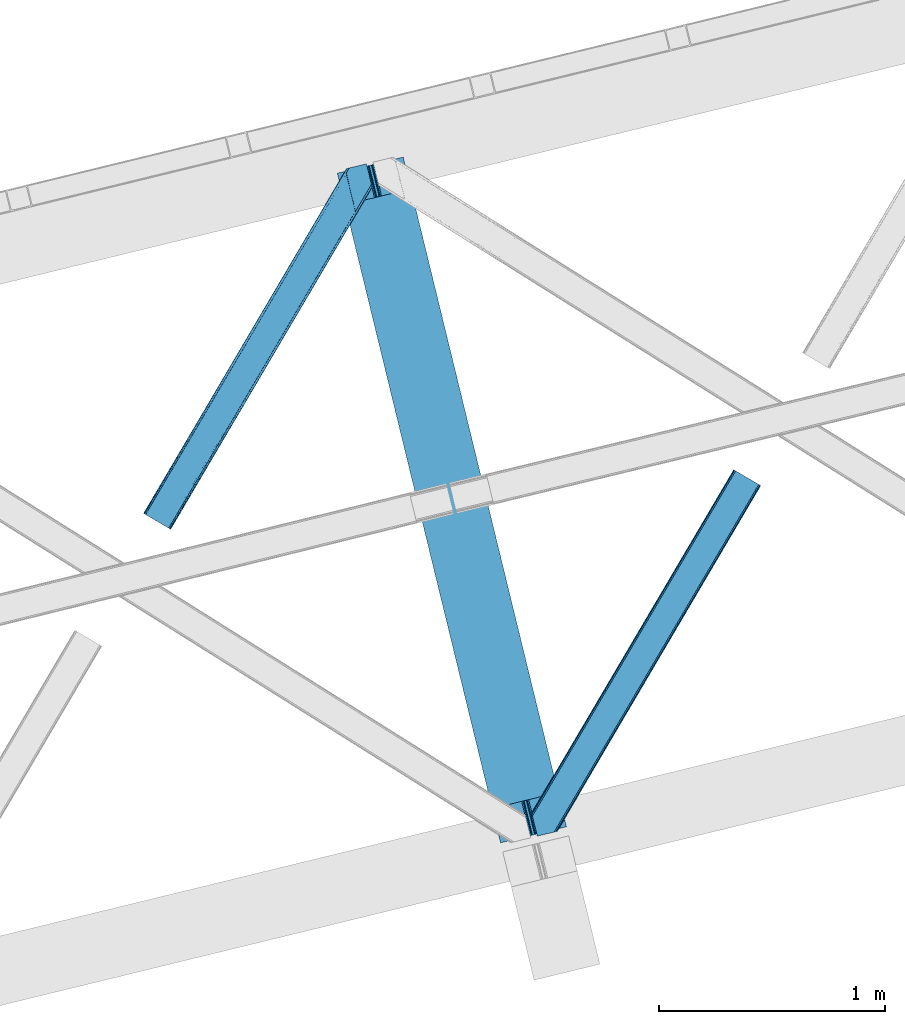
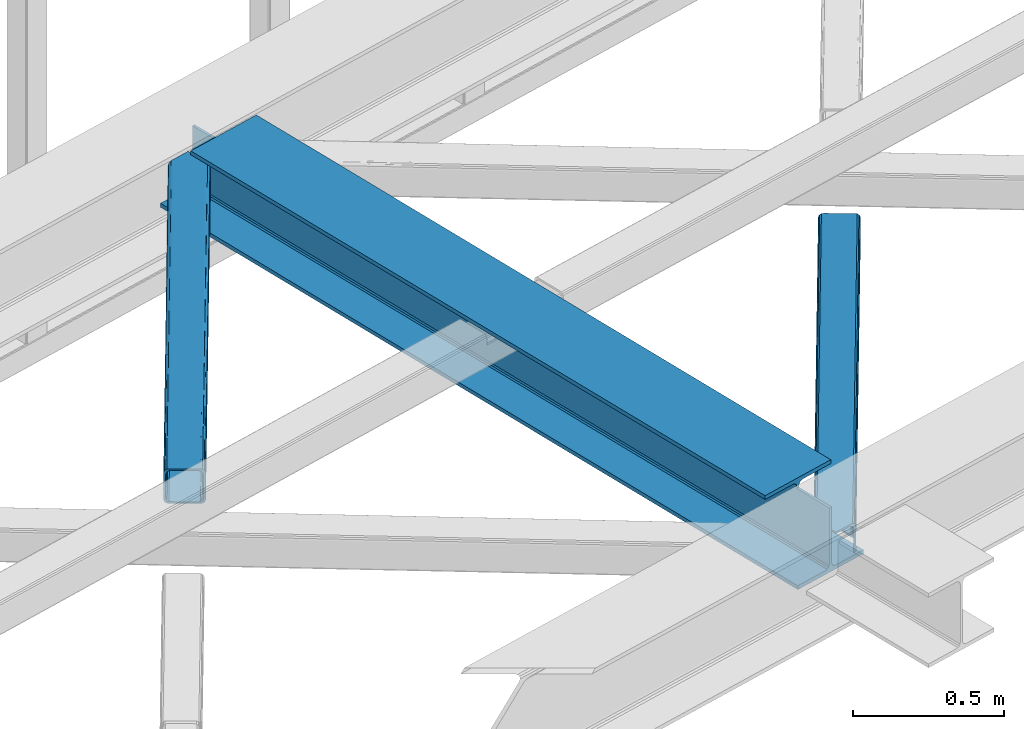
# One storey, part 19 of 67: 2 members, 1 beam.
"""IFC4 building model written with IfcOpenShell, lengths in millimetres."""

from ifc_helpers import new_model, entity, si_unit, converted_unit, derived_unit, direction, frame, origin, place, context, subcontext, project, spatial, triangles, polygons, material, type_object, element, save


model = new_model("IFC4")

# Units and contexts
model_context = context("Model", 3, precision=0.01, world=origin(), true_north=direction((6.12303176911189e-17, 1.0)))
plan_context = context("Plan", 3, precision=0.01, world=origin(), true_north=direction((6.12303176911189e-17, 1.0)))
body_context = subcontext(model_context, "Body", "Model", "MODEL_VIEW")
ifc_project = project(units=[si_unit("LENGTHUNIT", "METRE", prefix="MILLI"), si_unit("AREAUNIT", "SQUARE_METRE"), si_unit("VOLUMEUNIT", "CUBIC_METRE"), converted_unit("PLANEANGLEUNIT", "DEGREE", entity("IfcRatioMeasure", 0.0174532925199433), si_unit("PLANEANGLEUNIT", "RADIAN"), dimensions=[0, 0, 0, 0, 0, 0, 0]), si_unit("MASSUNIT", "GRAM", prefix="KILO"), derived_unit("MASSDENSITYUNIT", [(si_unit("MASSUNIT", "GRAM", prefix="KILO"), 1), (si_unit("LENGTHUNIT", "METRE"), -3)]), derived_unit("MOMENTOFINERTIAUNIT", [(si_unit("LENGTHUNIT", "METRE"), 4)]), si_unit("TIMEUNIT", "SECOND"), si_unit("FREQUENCYUNIT", "HERTZ"), si_unit("THERMODYNAMICTEMPERATUREUNIT", "DEGREE_CELSIUS"), derived_unit("THERMALTRANSMITTANCEUNIT", [(si_unit("MASSUNIT", "GRAM", prefix="KILO"), 1), (si_unit("THERMODYNAMICTEMPERATUREUNIT", "KELVIN"), -1), (si_unit("TIMEUNIT", "SECOND"), -3)]), derived_unit("VOLUMETRICFLOWRATEUNIT", [(si_unit("LENGTHUNIT", "METRE"), 3), (si_unit("TIMEUNIT", "SECOND"), -1)]), derived_unit("MASSFLOWRATEUNIT", [(si_unit("MASSUNIT", "GRAM", prefix="KILO"), 1), (si_unit("TIMEUNIT", "SECOND"), -1)]), derived_unit("ROTATIONALFREQUENCYUNIT", [(si_unit("TIMEUNIT", "SECOND"), -1)]), si_unit("ELECTRICCURRENTUNIT", "AMPERE"), si_unit("ELECTRICVOLTAGEUNIT", "VOLT"), si_unit("POWERUNIT", "WATT"), si_unit("FORCEUNIT", "NEWTON", prefix="KILO"), si_unit("ILLUMINANCEUNIT", "LUX"), si_unit("LUMINOUSFLUXUNIT", "LUMEN"), si_unit("LUMINOUSINTENSITYUNIT", "CANDELA"), derived_unit("USERDEFINED", [(si_unit("MASSUNIT", "GRAM", prefix="KILO"), -1), (si_unit("LENGTHUNIT", "METRE"), -2), (si_unit("TIMEUNIT", "SECOND"), 3), (si_unit("LUMINOUSFLUXUNIT", "LUMEN"), 1)]), derived_unit("LINEARVELOCITYUNIT", [(si_unit("LENGTHUNIT", "METRE"), 1), (si_unit("TIMEUNIT", "SECOND"), -1)]), si_unit("PRESSUREUNIT", "PASCAL"), derived_unit("USERDEFINED", [(si_unit("LENGTHUNIT", "METRE"), -2), (si_unit("MASSUNIT", "GRAM", prefix="KILO"), 1), (si_unit("TIMEUNIT", "SECOND"), -2)]), derived_unit("LINEARFORCEUNIT", [(si_unit("MASSUNIT", "GRAM", prefix="KILO"), 1), (si_unit("LENGTHUNIT", "METRE"), 1), (si_unit("TIMEUNIT", "SECOND"), -2), (si_unit("LENGTHUNIT", "METRE"), -1)]), derived_unit("PLANARFORCEUNIT", [(si_unit("MASSUNIT", "GRAM", prefix="KILO"), 1), (si_unit("LENGTHUNIT", "METRE"), 1), (si_unit("TIMEUNIT", "SECOND"), -2), (si_unit("LENGTHUNIT", "METRE"), -2)])], contexts=[model_context, plan_context])

# Site, building, storey
site_placement = place(None, origin())
site = spatial("IfcSite", under=ifc_project, at=site_placement, CompositionType="ELEMENT")
building_placement = place(site_placement, origin())
building = spatial("IfcBuilding", under=site, at=building_placement, CompositionType="ELEMENT")
storey_placement = place(building_placement, frame((0.0, 0.0, 19800.0)))
storey = spatial("IfcBuildingStorey", under=building, at=storey_placement, CompositionType="ELEMENT", Elevation=19800.0)

# Beam
ifc_material = material(Name="Metal painted (White)")
beam_type = type_object("IfcBeamType", PredefinedType="BEAM")
beam_placement = place(storey_placement, frame((-58234.7830604504, 3608.48007370512, 3807.02022389142)))
element("IfcBeam", 1, at=beam_placement, inside=storey, type_object=beam_type, material=ifc_material, ObjectType="Steel Beam", PredefinedType="BEAM", context=body_context, shape_type="Tessellation", body=[
    polygons([(291.465617442438, 3033.06716515592, 15.5000000000008), (1013.48916844672, 71.047827897101, 15.5000000000008), (1013.48916844672, 71.047827897101, 0.0), (291.465617442438, 3033.06716515592, 0.0), (168.078506058465, 3002.99025134615, 15.5000000000008), (890.102057062761, 40.9709140873291, 15.5000000000008), (883.409713288798, 39.3395844888243, 16.8701684147984), (161.386162284511, 3001.35892174764, 16.8701684147984), (877.736218188182, 37.9566100336502, 20.7720779386434), (155.712667183895, 2999.97594729247, 20.7720779386434), (873.945309959616, 37.0325360459167, 26.6116982174294), (151.92175895532, 2999.05187330474, 26.6116982174294), (872.614120016219, 36.7080444135018, 33.500000000001), (150.590569011932, 2998.72738167232, 33.500000000001), (140.875048430505, 2996.35912074242, 33.500000000001), (140.875048430505, 2996.35912074242, 259.000000000002), (150.590569011932, 2998.72738167232, 259.000000000002), (0.0, 2962.01933725882, 0.0), (0.0, 2962.01933725882, 15.4999999999965), (123.387111383964, 2992.09625106859, 15.5000000000008), (130.079455157926, 2993.7275806671, 16.8701684147984), (135.752950258542, 2995.11055512227, 20.7720779386434), (139.543858487109, 2996.03462911, 26.6116982174294), (862.898599434792, 34.3397834835981, 259.000000000002), (862.898599434792, 34.3397834835992, 33.500000000001), (861.567409491404, 34.0152918511837, 26.6116982174294), (857.776501262829, 33.0912178634502, 20.7720779386434), (852.103006162213, 31.7082434082767, 16.8701684147984), (845.410662388251, 30.0769138097719, 15.5000000000008), (722.023551004287, 0.0, 15.4999999999965), (722.023551004287, 5.41433564649196e-13, 0.0), (872.614120016219, 36.7080444135018, 259.000000000002), (184.336875281427, 2860.28691509782, 264.979820882044), (184.752732925781, 2858.58099728541, 264.979776108577), (184.752732925781, 2858.58099728541, 266.5), (835.611083878222, 188.508783434825, 266.500002998871), (835.611433998983, 188.507347130091, 260.000004007589), (835.756262659236, 187.913305519903, 259.069792895655), (184.10148419006, 2861.25277281279, 259.006343165873), (184.321671892423, 2860.34946683221, 259.617271795417), (175.037212344371, 2856.21273635551, 264.979776108577), (174.624287332073, 2857.90681193203, 264.979727889257), (174.621246070538, 2857.91909282363, 260.000048218074), (174.476547052887, 2858.51270029145, 259.069794411205), (826.131325439436, 185.173233288697, 259.006343169741), (825.907955396203, 186.089684915033, 259.617303331124), (825.895566552569, 186.140509148806, 266.500003008253), (175.037212344371, 2856.21273635551, 266.5), (173.706022400984, 2855.8882447231, 273.388301782572), (169.915114172408, 2854.96417073536, 279.227922061358), (164.241619071775, 2853.58119628019, 283.129831585203), (157.549275297821, 2851.94986668168, 284.5), (34.1621639138576, 2821.87295287191, 284.5), (34.1621639138576, 2821.87295287191, 300.000000000001), (325.627781356295, 2892.92078076901, 300.000000000001), (325.627781356295, 2892.92078076901, 284.5), (202.240669972323, 2862.84386695924, 284.5), (195.548326198377, 2861.21253736074, 283.129831585203), (189.874831097753, 2859.82956290556, 279.227922061358), (186.083922869178, 2858.90548891783, 273.388301782572), (836.942571748158, 188.832052879511, 273.388305639783), (840.732848336854, 189.758718051425, 279.227924098781), (846.405919284392, 191.143432515101, 283.129832400619), (853.098110965509, 192.775386045914, 284.500000377228), (976.485139653361, 222.852639101025, 284.500000138971), (976.483469846701, 222.859489169757, 299.999995328161), (685.018047749439, 151.810859905715, 299.999995890962), (685.019717556091, 151.804009836983, 284.500000701776), (808.406746243935, 181.881262892094, 284.500000463519), (815.099233140082, 183.512005358672, 283.129832461069), (820.773144788834, 184.893271003198, 279.227924137322), (824.564679575826, 185.814774652495, 273.388305663684)], [[[1, 2, 3, 4]], [[5, 6, 2, 1]], [[7, 6, 5, 8]], [[9, 7, 8, 10]], [[11, 9, 10, 12]], [[13, 11, 12, 14]], [[15, 16, 17, 14, 12, 10, 8, 5, 1, 4, 18, 19, 20, 21, 22, 23]], [[24, 25, 26, 27, 28, 29, 30, 31, 3, 2, 6, 7, 9, 11, 13, 32]], [[4, 3, 31, 18]], [[18, 31, 30, 19]], [[19, 30, 29, 20]], [[26, 25, 15, 23]], [[27, 26, 23, 22]], [[28, 27, 22, 21]], [[29, 28, 21, 20]], [[33, 34, 35, 36, 37, 38, 32, 13, 14, 17, 39, 40]], [[41, 42, 43, 44, 16, 15, 25, 24, 45, 46, 47, 48]], [[44, 39, 17, 16]], [[42, 33, 40, 43]], [[42, 41, 34, 33]], [[45, 24, 32, 38]], [[41, 48, 49, 50, 51, 52, 53, 54, 55, 56, 57, 58, 59, 60, 35, 34]], [[47, 46, 37, 36, 61, 62, 63, 64, 65, 66, 67, 68, 69, 70, 71, 72]], [[61, 36, 35, 60]], [[62, 61, 60, 59]], [[63, 62, 59, 58]], [[64, 63, 58, 57]], [[57, 56, 65, 64]], [[56, 55, 66, 65]], [[55, 54, 67, 66]], [[54, 53, 68, 67]], [[53, 52, 69, 68]], [[70, 69, 52, 51]], [[71, 70, 51, 50]], [[72, 71, 50, 49]], [[47, 72, 49, 48]]], closed=False),
])

# Members
member_type_1 = type_object("IfcMemberType", PredefinedType="BRACE")
member_1_placement = place(storey_placement, frame((-59092.2442382813, 4994.98929748535, 3823.99987792968)))
element("IfcMember", 2, at=member_1_placement, inside=storey, type_object=member_type_1, ObjectType="Steel Horizontal Brace", PredefinedType="BRACE", context=body_context, shape_type="Tessellation", body=[
    triangles([(105.565649414064, 8.87794647216742, 0.0), (15.0828002929702, 62.1479507446284, 0.0), (892.847827148435, 1346.1393447876, 0.0), (857.170935058595, 1492.50250396728, 0.0), (854.896655273435, 1501.83739929199, 1.33247680664135), (9.31105957031104, 65.5459991455073, 1.33247680664135), (852.966540527341, 1509.75145111084, 5.12526855468968), (4.4183349609375, 68.4260559082031, 5.12526855468968), (851.678247070311, 1515.03950042725, 10.8039916992202), (1.14876708984229, 70.3509384155268, 10.8039916992202), (851.222460937497, 1516.89636383057, 17.5012573242202), (0.0, 71.0264785766603, 17.5012573242202), (893.638476562497, 1342.89768218994, 0.155804443358647), (111.337390136716, 5.48047943115216, 1.33247680664135), (899.559045410155, 1344.34119873047, 1.33247680664135), (912.390820312503, 1347.46949615478, 10.8039916992202), (914.195361328122, 1347.90958557129, 17.5012573242202), (120.643798828125, 0.0, 17.5012573242202), (119.499682617185, 0.675540161132631, 10.8039916992202), (907.251599121097, 1346.21666564941, 5.12526855468968), (116.230114746089, 2.59984130859357, 5.12526855468968), (902.498400878903, 1345.05743408203, 17.9802978515618), (893.638476562497, 1342.89768218994, 9.69243164062573), (897.768457031249, 1343.90459747314, 12.1248413085959), (903.726232910158, 1345.35625305176, 19.5011352539077), (914.195361328122, 1347.90958557129, 19.5011352539077), (1011.61732177735, 1513.38611297607, 19.5011352539077), (1008.98957519532, 1524.16103668213, 19.5011352539077), (1011.61732177735, 1513.38611297607, 122.499499511719), (120.643798828125, 0.0, 122.499499511719), (114.61160888672, 3.55094604492206, 24.5008300781265), (1009.24072265625, 1523.14365692139, 24.5008300781265), (113.46749267578, 4.22706756591742, 17.8035644531265), (110.197924804685, 6.15136871337836, 12.1248413085959), (105.305200195311, 9.03200683593695, 8.3320495605476), (99.5334594726519, 12.4294738769531, 6.99957275390625), (892.685046386716, 1346.79976959229, 8.8831787109375), (890.471228027345, 1355.89688873291, 6.99957275390625), (21.114990234375, 58.5970046997072, 6.99957275390625), (859.547534179685, 1482.74496002197, 6.99957275390625), (853.961828613283, 1505.65984039307, 18.501196289064), (851.222460937497, 1516.89636383057, 18.501196289064), (854.096704101561, 1505.10871124268, 17.8803039550803), (855.343139648438, 1499.99390716553, 12.1248413085959), (857.273254394531, 1492.07985534668, 8.3320495605476), (1009.24072265625, 1523.14365692139, 115.499926757813), (114.61160888672, 3.55094604492206, 115.499926757813), (1008.78493652344, 1525.00052032471, 122.197192382813), (113.46749267578, 4.22706756591742, 122.197192382813), (1007.49664306641, 1530.28856964111, 127.873590087893), (110.197924804685, 6.15136871337836, 127.873590087893), (1005.57117919922, 1538.20262145996, 131.668707275392), (105.305200195311, 9.03200683593695, 131.668707275392), (1003.29224853516, 1547.53751678467, 133.001184082033), (99.5334594726519, 12.4294738769531, 133.001184082033), (851.952648925784, 1518.13291625977, 19.5011352539077), (854.580395507815, 1507.35799255371, 19.5011352539077), (851.780566406247, 1517.83991088867, 19.2639404296897), (854.43156738281, 1506.94987792969, 19.2592895507805), (851.589880371095, 1517.51434936523, 19.0011657714858), (854.268786621091, 1506.50920715332, 19.0011657714858), (851.394543457034, 1517.1887878418, 18.7360656738274), (854.110656738281, 1506.06795501709, 18.7407165527366), (908.014343261719, 1598.12628936768, 19.5011352539077), (897.545214843747, 1595.57353820801, 19.5011352539077), (1011.16618652343, 1515.24297637939, 129.196765136719), (1009.8778930664, 1520.53160705566, 134.87548828125), (1008.43146972657, 1526.45624542236, 138.000878906252), (986.311889648438, 1617.21117095947, 138.000878906252), (986.311889648438, 1617.21117095947, 133.001184082033), (897.545214843747, 1595.57353820801, 122.499499511719), (0.0, 71.0264785766603, 122.499499511719), (7.18095703124709, 66.799411010742, 17.8035644531265), (10.4505249023423, 64.8751098632811, 12.1248413085959), (6.03218994140479, 67.4755325317383, 24.5008300781265), (907.028356933595, 1597.88560638428, 24.5008300781265), (15.3432495117158, 61.9944717407225, 8.3320495605476), (908.832897949222, 1598.32511444092, 122.197192382813), (899.349755859374, 1596.01362762451, 129.196765136719), (904.48897705078, 1597.26645812988, 134.87548828125), (930.738537597659, 1603.66490478516, 133.001184082033), (910.246765136719, 1598.66986083984, 138.000878906252), (921.664672851563, 1601.45341186523, 131.668707275392), (913.972119140628, 1599.57794494629, 127.873590087893), (907.028356933595, 1597.88560638428, 115.499926757813), (21.114990234375, 58.5970046997072, 133.001184082033), (6.03218994140479, 67.4755325317383, 115.499926757813), (15.3432495117158, 61.9944717407225, 131.668707275392), (10.4505249023423, 64.8751098632811, 127.873590087893), (7.18095703124709, 66.799411010742, 122.197192382813), (119.499682617185, 0.675540161132631, 129.196765136719), (116.230114746089, 2.59984130859357, 134.87548828125), (111.337390136716, 5.48047943115216, 138.668280029298), (105.565649414064, 8.87794647216742, 140.00075683594), (15.0828002929702, 62.1479507446284, 140.00075683594), (9.31105957031104, 65.5459991455073, 138.668280029298), (4.4183349609375, 68.4260559082031, 134.87548828125), (1.14876708984229, 70.3509384155268, 129.196765136719), (896.991760253906, 1576.15553741455, 138.000878906252), (938.18924560547, 1407.14434204102, 138.000878906252), (899.024194335936, 1563.5946762085, 140.00075683594), (897.042919921878, 1571.72266845703, 139.000817871096), (896.801074218747, 1573.13653564453, 138.638049316407), (896.926647949222, 1575.15443572998, 138.212493896484), (896.86153564453, 1574.14112548828, 138.426434326171), (937.477661132813, 1407.08562469482, 138.293884277344), (937.077685546872, 1408.09486541748, 138.647351074218), (936.682360839841, 1409.10410614014, 139.000817871096), (934.701086425783, 1417.23209838867, 140.00075683594)], [[1, 2, 3], [4, 3, 2], [5, 4, 6], [2, 6, 4], [7, 5, 8], [6, 8, 5], [9, 7, 10], [8, 10, 7], [11, 9, 12], [10, 12, 9], [1, 3, 13], [13, 14, 1], [13, 15, 14], [16, 17, 18], [18, 19, 16], [20, 16, 19], [19, 21, 20], [15, 20, 21], [21, 14, 15], [20, 22, 16], [23, 24, 15], [23, 15, 13], [15, 24, 20], [16, 25, 17], [20, 24, 22], [16, 22, 25], [26, 17, 25], [26, 25, 27], [28, 27, 25], [27, 29, 26], [30, 26, 29], [26, 18, 17], [30, 18, 26], [31, 32, 25], [25, 33, 31], [25, 22, 33], [32, 28, 25], [33, 22, 24], [34, 24, 23], [23, 35, 34], [36, 35, 37], [37, 38, 36], [23, 37, 35], [24, 34, 33], [39, 36, 38], [38, 40, 39], [9, 11, 41], [11, 42, 41], [43, 9, 41], [43, 7, 9], [44, 7, 43], [5, 44, 45], [44, 5, 7], [4, 5, 45], [45, 40, 4], [37, 23, 13], [37, 3, 38], [3, 40, 38], [40, 3, 4], [37, 13, 3], [46, 32, 31], [31, 47, 46], [48, 46, 49], [47, 49, 46], [50, 48, 51], [49, 51, 48], [52, 50, 53], [51, 53, 50], [54, 52, 55], [53, 55, 52], [56, 57, 58], [59, 58, 57], [58, 59, 60], [61, 60, 59], [60, 61, 62], [63, 62, 61], [62, 63, 42], [41, 42, 63], [57, 56, 64], [65, 64, 56], [66, 48, 67], [46, 29, 27], [27, 32, 46], [32, 27, 28], [48, 29, 46], [66, 29, 48], [50, 68, 67], [52, 68, 50], [67, 48, 50], [52, 54, 68], [54, 69, 68], [70, 69, 54], [71, 60, 62], [58, 60, 71], [71, 56, 58], [56, 71, 65], [42, 12, 72], [12, 42, 11], [71, 42, 72], [42, 71, 62], [73, 74, 44], [75, 73, 43], [43, 41, 75], [43, 57, 75], [64, 76, 57], [75, 57, 76], [44, 43, 73], [45, 44, 74], [74, 77, 45], [40, 45, 77], [77, 39, 40], [78, 79, 80], [81, 82, 69], [69, 70, 81], [81, 83, 82], [84, 82, 83], [80, 82, 84], [78, 71, 79], [85, 71, 78], [80, 84, 78], [65, 76, 64], [85, 65, 71], [76, 65, 85], [86, 54, 55], [54, 86, 81], [70, 54, 81], [76, 85, 75], [87, 75, 85], [83, 81, 86], [86, 88, 83], [84, 83, 88], [88, 89, 84], [78, 84, 89], [89, 90, 78], [85, 78, 90], [90, 87, 85], [91, 51, 49], [47, 18, 30], [91, 49, 30], [91, 92, 51], [49, 47, 30], [51, 92, 93], [55, 94, 95], [94, 53, 93], [53, 94, 55], [53, 51, 93], [19, 34, 21], [31, 18, 47], [18, 33, 19], [33, 18, 31], [19, 33, 34], [1, 36, 2], [14, 21, 34], [34, 35, 14], [35, 36, 1], [1, 14, 35], [89, 96, 97], [95, 86, 55], [95, 88, 86], [88, 95, 96], [89, 88, 96], [87, 72, 12], [98, 90, 89], [97, 98, 89], [90, 98, 72], [87, 90, 72], [6, 74, 8], [2, 36, 39], [39, 77, 2], [77, 74, 6], [6, 2, 77], [10, 8, 74], [12, 75, 87], [73, 12, 10], [12, 73, 75], [73, 10, 74], [99, 68, 82], [99, 100, 68], [68, 69, 82], [96, 95, 101], [101, 102, 96], [97, 96, 103], [104, 97, 105], [104, 99, 97], [97, 103, 105], [82, 80, 99], [97, 99, 80], [102, 103, 96], [79, 71, 98], [72, 98, 71], [80, 79, 97], [98, 97, 79], [92, 67, 100], [100, 93, 92], [67, 68, 100], [106, 107, 93], [94, 93, 107], [107, 108, 94], [108, 109, 94], [66, 67, 92], [92, 91, 66], [29, 66, 91], [91, 30, 29], [95, 94, 109], [109, 101, 95], [107, 103, 102], [105, 103, 107], [106, 104, 105], [100, 99, 104], [107, 106, 105], [102, 108, 107], [102, 101, 109], [109, 108, 102]]),
])
member_type_2 = type_object("IfcMemberType", PredefinedType="BRACE")
member_2_placement = place(storey_placement, frame((-57375.3955444336, 3638.09770202637, 3823.99987792968)))
element("IfcMember", 3, at=member_2_placement, inside=storey, type_object=member_type_2, ObjectType="Steel Horizontal Brace", PredefinedType="BRACE", context=body_context, shape_type="Tessellation", body=[
    triangles([(154.446386718751, 124.708666992188, 0.0), (118.769494628905, 271.071535491943, 0.0), (998.971582031249, 1559.19843292236, 0.0), (908.488732910155, 1612.46901855469, 0.0), (1004.74332275391, 1555.80096588135, 1.33247680664135), (156.725317382814, 115.37377166748, 1.33247680664135), (1009.63604736328, 1552.92090911865, 5.12526855468968), (158.650781249999, 107.459719848633, 5.12526855468968), (1012.90561523438, 1550.99602661133, 10.8039916992202), (159.943725585938, 102.171670532227, 10.8039916992202), (1014.05438232422, 1550.3204864502, 17.5012573242202), (160.394860839842, 100.314807128907, 17.5012573242202), (902.716992187503, 1615.8664855957, 1.33247680664135), (116.495214843751, 280.406721496582, 1.33247680664135), (114.574401855469, 288.275717926026, 5.1694519042976), (897.824267578122, 1618.74712371826, 5.12526855468968), (114.499987792966, 288.596628570557, 5.32758178711083), (894.554699707034, 1620.67142486572, 10.8039916992202), (109.625866699222, 287.409201049805, 10.8039916992202), (893.405932617185, 1621.34696502686, 17.5012573242202), (107.821325683595, 286.969111633301, 17.5012573242202), (113.527954101563, 288.35972442627, 18.5197998046897), (114.499987792966, 288.596628570557, 17.5198608398459), (114.42557373047, 288.578606414795, 17.9035583496116), (114.216284179689, 288.527156066895, 18.2267944335945), (113.900024414063, 288.450416564941, 18.4453857421868), (107.821325683595, 286.969111633301, 18.5197998046897), (115.695263671878, 283.683556365967, 17.5198608398459), (115.625500488284, 283.800409698486, 17.8035644531265), (115.565039062501, 283.740529632569, 17.8570495605491), (115.323193359378, 283.495777130127, 18.0779663085959), (115.067395019534, 283.23939743042, 18.3081848144539), (114.834851074222, 283.003074645996, 18.5197998046897), (0.0, 103.824767303467, 18.5197998046897), (2.73471679687646, 92.5989990234375, 18.5197998046897), (893.405932617185, 1621.34696502686, 122.499499511719), (0.0, 103.824767303467, 122.499499511719), (908.488732910155, 1612.46901855469, 140.00075683594), (902.716992187503, 1615.8664855957, 138.668280029298), (3.66954345702834, 88.7660934448245, 138.668280029298), (5.94847412109084, 79.4309074401858, 140.00075683594), (897.824267578122, 1618.74712371826, 134.87548828125), (1.73942871093459, 96.6798545837405, 134.87548828125), (894.554699707034, 1620.67142486572, 129.196765136719), (0.451135253904795, 101.967903900147, 129.196765136719), (899.438122558597, 1617.79601898193, 24.5008300781265), (2.37659912109666, 94.0672233581545, 24.5008300781265), (900.586889648439, 1617.11989746094, 17.8035644531265), (903.856457519534, 1615.19559631348, 12.1248413085959), (914.52092285156, 1608.9174911499, 6.99957275390625), (908.749182128908, 1612.31495819092, 8.3320495605476), (118.871813964841, 270.64917755127, 8.3320495605476), (121.150744628903, 261.313991546631, 6.99957275390625), (116.946350097656, 278.562938690186, 12.1248413085959), (152.069787597655, 134.4662109375, 6.99957275390625), (992.939392089844, 1562.74996032715, 6.99957275390625), (156.274182128909, 117.217263793946, 12.1248413085959), (154.344067382815, 125.131024932862, 8.3320495605476), (157.520617675778, 112.096646118164, 17.5198608398459), (160.394860839842, 100.314807128907, 17.5198608398459), (899.438122558597, 1617.79601898193, 115.499926757813), (2.37659912109666, 94.0672233581545, 115.499926757813), (900.586889648439, 1617.11989746094, 122.197192382813), (2.83238525390334, 92.2103599548341, 122.197192382813), (903.856457519534, 1615.19559631348, 127.873590087893), (4.12067871094041, 86.9223106384279, 127.873590087893), (908.749182128908, 1612.31495819092, 131.668707275392), (6.05079345703416, 79.0085494995119, 131.668707275392), (914.52092285156, 1608.9174911499, 133.001184082033), (8.3250732421875, 69.6733634948732, 133.001184082033), (25.310083007811, 0.0, 133.001184082033), (25.310083007811, 0.0, 140.00075683594), (90.3665771484375, 15.8580436706543, 140.00075683594), (998.971582031249, 1559.19843292236, 140.00075683594), (1014.05438232422, 1550.3204864502, 122.499499511719), (1012.90561523438, 1550.99602661133, 129.196765136719), (114.076757812501, 21.6376327514649, 122.499499511719), (112.267565917966, 21.1978340148926, 129.196765136719), (1009.63604736328, 1552.92090911865, 134.87548828125), (107.12834472656, 19.9450035095215, 134.87548828125), (1004.74332275391, 1555.80096588135, 138.668280029298), (99.435791015625, 18.0698272705081, 138.668280029298), (159.664672851563, 99.0785453796389, 18.5197998046897), (114.076757812501, 21.6376327514649, 18.5197998046897), (103.161145019534, 18.9779113769532, 18.5197998046897), (156.929956054686, 110.304313659668, 18.5197998046897), (1008.02219238281, 1553.87143249512, 24.5008300781265), (1006.87342529297, 1554.54755401611, 17.8035644531265), (1003.60385742188, 1556.47185516357, 12.1248413085959), (998.711132812503, 1559.35249328613, 8.3320495605476), (104.588964843751, 19.325855255127, 24.5008300781265), (1003.60385742188, 1556.47185516357, 127.873590087893), (1008.02219238281, 1553.87143249512, 115.499926757813), (1006.87342529297, 1554.54755401611, 122.197192382813), (992.939392089844, 1562.74996032715, 133.001184082033), (998.711132812503, 1559.35249328613, 131.668707275392), (102.784423828125, 18.8860565185546, 122.197192382813), (80.8787841796875, 13.5462661743163, 133.001184082033), (89.9526489257842, 15.7580497741701, 131.668707275392), (97.6452026367188, 17.6329353332521, 127.873590087893), (104.588964843751, 19.325855255127, 115.499926757813)], [[1, 2, 3], [4, 3, 2], [3, 5, 1], [6, 1, 5], [5, 7, 6], [8, 6, 7], [7, 9, 8], [10, 8, 9], [9, 11, 10], [12, 10, 11], [13, 14, 15], [16, 15, 17], [17, 18, 16], [17, 19, 18], [20, 18, 19], [19, 21, 20], [15, 16, 13], [13, 4, 14], [2, 14, 4], [22, 23, 24], [22, 25, 26], [27, 21, 22], [24, 25, 22], [23, 22, 21], [21, 19, 23], [17, 23, 19], [23, 28, 29], [29, 24, 23], [25, 24, 30], [26, 25, 31], [22, 26, 32], [32, 33, 22], [31, 32, 26], [30, 31, 25], [29, 30, 24], [34, 33, 35], [33, 34, 27], [22, 33, 27], [27, 20, 21], [36, 27, 37], [27, 36, 20], [27, 34, 37], [38, 39, 40], [40, 41, 38], [39, 42, 43], [43, 40, 39], [42, 44, 45], [45, 43, 42], [44, 36, 37], [37, 45, 44], [46, 47, 33], [33, 48, 46], [33, 31, 48], [47, 35, 33], [49, 48, 28], [50, 51, 52], [52, 53, 50], [51, 49, 54], [54, 52, 51], [28, 54, 49], [53, 55, 56], [56, 50, 53], [55, 2, 1], [54, 17, 14], [52, 14, 2], [52, 2, 53], [55, 53, 2], [17, 28, 23], [54, 28, 17], [52, 54, 14], [57, 58, 6], [58, 1, 6], [1, 58, 55], [8, 57, 6], [8, 59, 57], [10, 59, 8], [10, 60, 59], [46, 61, 47], [62, 47, 61], [61, 63, 62], [64, 62, 63], [63, 65, 64], [66, 64, 65], [65, 67, 66], [68, 66, 67], [67, 69, 68], [70, 68, 69], [66, 43, 64], [71, 72, 70], [72, 41, 70], [40, 68, 41], [66, 68, 40], [68, 70, 41], [66, 40, 43], [37, 34, 62], [45, 64, 43], [62, 64, 37], [64, 45, 37], [34, 47, 62], [34, 35, 47], [41, 73, 74], [73, 41, 72], [74, 38, 41], [75, 76, 77], [78, 77, 76], [76, 79, 78], [80, 78, 79], [79, 81, 80], [82, 80, 81], [81, 74, 82], [73, 82, 74], [60, 75, 77], [60, 11, 75], [77, 83, 60], [77, 84, 83], [84, 85, 83], [86, 83, 85], [87, 88, 59], [88, 89, 57], [57, 59, 88], [89, 90, 58], [58, 57, 89], [90, 56, 55], [55, 58, 90], [87, 86, 91], [85, 91, 86], [9, 89, 88], [87, 75, 11], [9, 88, 11], [9, 7, 89], [88, 87, 11], [89, 7, 5], [56, 3, 4], [3, 90, 5], [90, 3, 56], [90, 89, 5], [76, 92, 79], [93, 75, 87], [75, 94, 76], [94, 75, 93], [76, 94, 92], [74, 95, 38], [81, 79, 92], [92, 96, 81], [96, 95, 74], [74, 81, 96], [49, 13, 16], [4, 50, 56], [4, 51, 50], [51, 4, 13], [49, 51, 13], [46, 20, 36], [18, 48, 49], [16, 18, 49], [48, 18, 20], [46, 48, 20], [39, 65, 42], [38, 95, 69], [69, 67, 38], [67, 65, 39], [39, 38, 67], [44, 42, 65], [36, 61, 46], [63, 36, 44], [36, 63, 61], [63, 44, 65], [97, 78, 80], [98, 73, 72], [72, 71, 98], [98, 99, 73], [99, 82, 73], [100, 82, 99], [80, 82, 100], [97, 77, 78], [101, 77, 97], [80, 100, 97], [84, 91, 85], [101, 84, 77], [91, 84, 101], [98, 70, 95], [98, 71, 70], [69, 95, 70], [95, 96, 99], [99, 98, 95], [96, 92, 100], [100, 99, 96], [92, 94, 97], [97, 100, 92], [94, 93, 101], [101, 97, 94], [93, 87, 91], [91, 101, 93]]),
])

save(model, "model.ifc")
